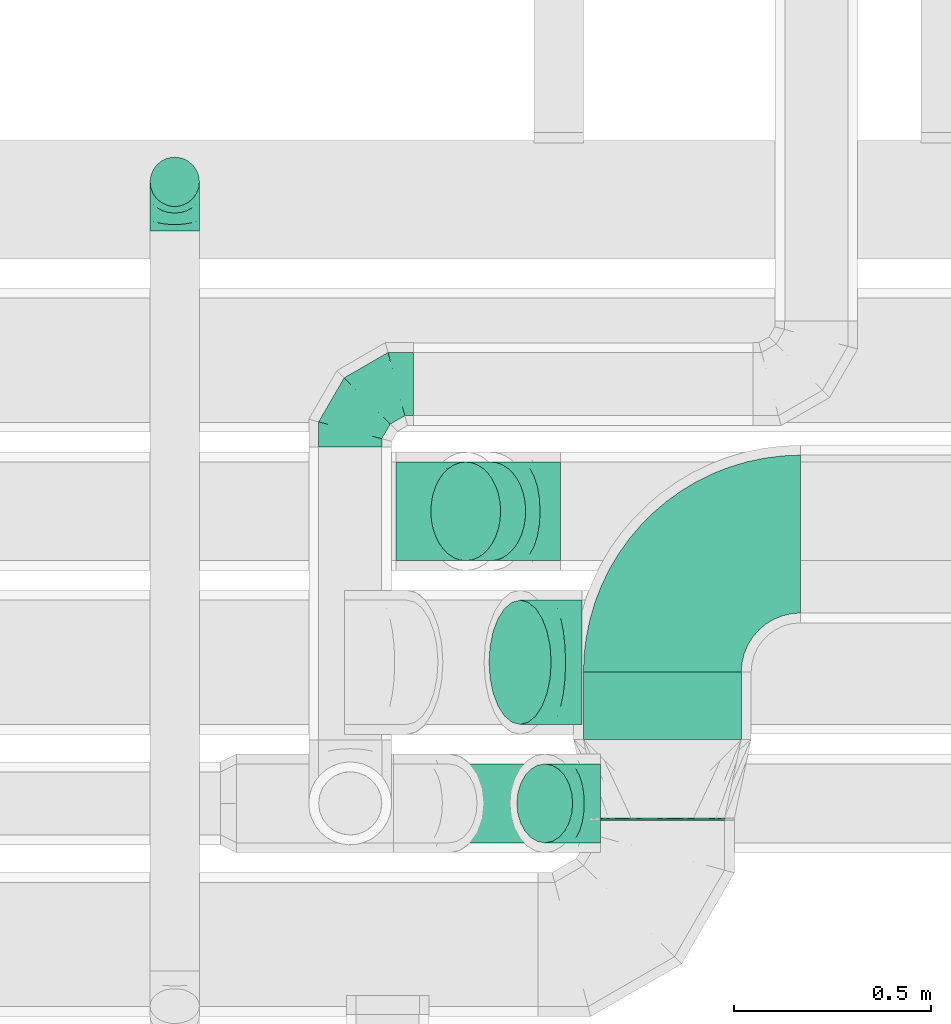
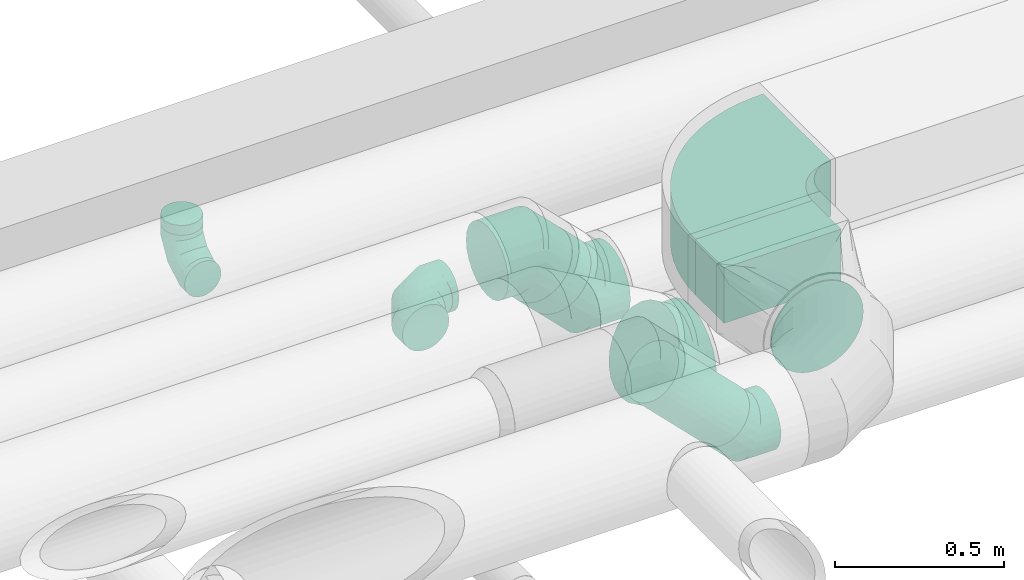
# One storey, part 58 of 92: 7 flow fittings, 5 flow segments.
"""IFC2X3 building model written with IfcOpenShell, lengths in millimetres."""

from ifc_helpers import new_model, entity, si_unit, converted_unit, derived_unit, direction, frame, frame_2d, origin, origin_2d_with_axis, place, context, subcontext, project, spatial, polyline, circle_curve, parameter, trimmed, segment, composite_curve, rectangle, circle, outline, extrude, faceted_brep, source, transform, mapped, material, type_object, type_shapes, element, save


model = new_model("IFC2X3")

# Units and contexts
model_context = context("Model", 3, precision=0.01, world=origin(), true_north=direction((6.12303176911189e-17, 1.0)))
body_context = subcontext(model_context, "Body", "Model", "MODEL_VIEW")
ifc_project = project(units=[si_unit("LENGTHUNIT", "METRE", prefix="MILLI"), si_unit("AREAUNIT", "SQUARE_METRE"), si_unit("VOLUMEUNIT", "CUBIC_METRE"), converted_unit("PLANEANGLEUNIT", "DEGREE", entity("IfcRatioMeasure", 0.0174532925199433), si_unit("PLANEANGLEUNIT", "RADIAN"), dimensions=[0, 0, 0, 0, 0, 0, 0]), si_unit("MASSUNIT", "GRAM", prefix="KILO"), derived_unit("MASSDENSITYUNIT", [(si_unit("MASSUNIT", "GRAM", prefix="KILO"), 1), (si_unit("LENGTHUNIT", "METRE"), -3)]), derived_unit("MOMENTOFINERTIAUNIT", [(si_unit("LENGTHUNIT", "METRE"), 4)]), si_unit("TIMEUNIT", "SECOND"), si_unit("FREQUENCYUNIT", "HERTZ"), si_unit("THERMODYNAMICTEMPERATUREUNIT", "DEGREE_CELSIUS"), derived_unit("THERMALTRANSMITTANCEUNIT", [(si_unit("MASSUNIT", "GRAM", prefix="KILO"), 1), (si_unit("THERMODYNAMICTEMPERATUREUNIT", "KELVIN"), -1), (si_unit("TIMEUNIT", "SECOND"), -3)]), derived_unit("VOLUMETRICFLOWRATEUNIT", [(si_unit("LENGTHUNIT", "METRE"), 3), (si_unit("TIMEUNIT", "SECOND"), -1)]), derived_unit("MASSFLOWRATEUNIT", [(si_unit("MASSUNIT", "GRAM", prefix="KILO"), 1), (si_unit("TIMEUNIT", "SECOND"), -1)]), derived_unit("ROTATIONALFREQUENCYUNIT", [(si_unit("TIMEUNIT", "SECOND"), -1)]), si_unit("ELECTRICCURRENTUNIT", "AMPERE"), si_unit("ELECTRICVOLTAGEUNIT", "VOLT"), si_unit("POWERUNIT", "WATT"), si_unit("FORCEUNIT", "NEWTON", prefix="KILO"), si_unit("ILLUMINANCEUNIT", "LUX"), si_unit("LUMINOUSFLUXUNIT", "LUMEN"), si_unit("LUMINOUSINTENSITYUNIT", "CANDELA"), derived_unit("USERDEFINED", [(si_unit("MASSUNIT", "GRAM", prefix="KILO"), -1), (si_unit("LENGTHUNIT", "METRE"), -2), (si_unit("TIMEUNIT", "SECOND"), 3), (si_unit("LUMINOUSFLUXUNIT", "LUMEN"), 1)]), derived_unit("LINEARVELOCITYUNIT", [(si_unit("LENGTHUNIT", "METRE"), 1), (si_unit("TIMEUNIT", "SECOND"), -1)]), si_unit("PRESSUREUNIT", "PASCAL"), derived_unit("USERDEFINED", [(si_unit("LENGTHUNIT", "METRE"), -2), (si_unit("MASSUNIT", "GRAM", prefix="KILO"), 1), (si_unit("TIMEUNIT", "SECOND"), -2)]), derived_unit("LINEARFORCEUNIT", [(si_unit("MASSUNIT", "GRAM", prefix="KILO"), 1), (si_unit("LENGTHUNIT", "METRE"), 1), (si_unit("TIMEUNIT", "SECOND"), -2), (si_unit("LENGTHUNIT", "METRE"), -1)]), derived_unit("PLANARFORCEUNIT", [(si_unit("MASSUNIT", "GRAM", prefix="KILO"), 1), (si_unit("LENGTHUNIT", "METRE"), 1), (si_unit("TIMEUNIT", "SECOND"), -2), (si_unit("LENGTHUNIT", "METRE"), -2)])], contexts=[model_context])

# Site, building, storey
site_placement = place(None, origin())
site = spatial("IfcSite", under=ifc_project, at=site_placement, CompositionType="ELEMENT")
building_placement = place(site_placement, origin())
building = spatial("IfcBuilding", under=site, at=building_placement, CompositionType="ELEMENT")
storey_placement = place(building_placement, frame((0.0, 0.0, 4200.0)))
storey = spatial("IfcBuildingStorey", under=building, at=storey_placement, CompositionType="ELEMENT", Elevation=4200.0)

# Flow segments
duct_segment_type_1 = type_object("IfcDuctSegmentType", PredefinedType="NOTDEFINED")
flow_segment_1_placement = place(storey_placement, frame((47020.11, 14762.0, 3257.5)))
element("IfcFlowSegment", 1, at=flow_segment_1_placement, inside=storey, type_object=duct_segment_type_1, context=body_context, shape_type="SweptSolid", body=[
    extrude(rectangle(XDim=170.00000000002, YDim=400.000000000004, at=origin_2d_with_axis()), frame((200.0, 85.0, 0.0), z_axis=(0.0, 0.0, 1.0), x_axis=(0.0, -1.0, 0.0)), (0.0, 0.0, 1.0), 200.0),
])
duct_segment_type_2 = type_object("IfcDuctSegmentType", PredefinedType="NOTDEFINED")
flow_segment_2_placement = place(storey_placement, frame((45920.46, 16110.42, 3125.0)))
element("IfcFlowSegment", 2, at=flow_segment_2_placement, inside=storey, type_object=duct_segment_type_2, context=body_context, shape_type="SweptSolid", body=[
    extrude(circle(Radius=62.5, at=origin_2d_with_axis()), frame((64.1, 64.1, 0.0)), (0.0, 0.0, 1.0), 35.3426558875469),
])
flow_segment_3_placement = place(storey_placement, frame((46607.52, 14497.9, 2986.27)))
element("IfcFlowSegment", 3, at=flow_segment_3_placement, inside=storey, type_object=duct_segment_type_2, context=body_context, shape_type="SweptSolid", body=[
    extrude(circle(Radius=100.0, at=origin_2d_with_axis()), frame((72.31, 101.6, 314.63), z_axis=(0.707106781186494, 0.0, -0.707106781186601), x_axis=(0.0, -1.0, 0.0)), (0.0, 0.0, 1.0), 342.697006973696),
])
flow_segment_4_placement = place(storey_placement, frame((46631.86, 15212.9, 3073.24)))
element("IfcFlowSegment", 4, at=flow_segment_4_placement, inside=storey, type_object=duct_segment_type_2, context=body_context, shape_type="SweptSolid", body=[
    extrude(circle(Radius=125.0, at=origin_2d_with_axis()), frame((89.98, 126.6, 153.54), z_axis=(0.707106792500144, 0.0, -0.707106769872951), x_axis=(0.0, 1.0, 0.0)), (0.0, 0.0, 1.0), 89.8780763498347),
])
flow_segment_5_placement = place(storey_placement, frame((47061.01, 14557.0, 3140.9)))
element("IfcFlowSegment", 5, at=flow_segment_5_placement, inside=storey, type_object=duct_segment_type_2, context=body_context, shape_type="SweptSolid", body=[
    extrude(circle(Radius=157.5, at=origin_2d_with_axis()), frame((159.1, 0.0, 159.1), z_axis=(0.0, 1.0, 0.0), x_axis=(1.0, 0.0, 0.0)), (0.0, 0.0, 1.0), 5.00000000002269),
])

# Flow fittings
ifc_material = material()
duct_fitting_type_1 = type_object("IfcDuctFittingType", PredefinedType="NOTDEFINED", material=ifc_material)
shared_shape_1 = source(origin(), body_context, "Body", "Brep", [
    faceted_brep([(-160.0, 0.0, -80.0), (-160.0, -20.71, -77.27), (-160.0, -40.0, -69.28), (-160.0, -56.57, -56.57), (-160.0, -69.28, -40.0), (-160.0, -77.27, -20.71), (-160.0, -80.0, 0.0), (-160.0, -77.27, 20.71), (-160.0, -69.28, 40.0), (-160.0, -56.57, 56.57), (-160.0, -40.0, 69.28), (-160.0, -20.71, 77.27), (-160.0, 0.0, 80.0), (-160.0, 20.71, 77.27), (-160.0, 40.0, 69.28), (-160.0, 56.57, 56.57), (-160.0, 69.28, 40.0), (-160.0, 77.27, 20.71), (-160.0, 80.0, 0.0), (-160.0, 77.27, -20.71), (-160.0, 69.28, -40.0), (-160.0, 56.57, -56.57), (-160.0, 40.0, -69.28), (-160.0, 20.71, -77.27), (-122.68, 20.71, 77.27), (-127.85, 40.0, 69.28), (-117.13, 0.0, 80.0), (-132.29, 56.57, 56.57), (-137.83, 77.27, 20.71), (-138.56, 80.0, 0.0), (-135.69, 69.28, 40.0), (-135.69, 69.28, -40.0), (-132.29, 56.57, -56.57), (-137.83, 77.27, -20.71), (-122.68, 20.71, -77.27), (-117.13, 0.0, -80.0), (-127.85, 40.0, -69.28), (-111.58, -20.71, -77.27), (-106.41, -40.0, -69.28), (-101.97, -56.57, -56.57), (-98.56, -69.28, -40.0), (-96.42, -77.27, -20.71), (-95.69, -80.0, 0.0), (-96.42, -77.27, 20.71), (-98.56, -69.28, 40.0), (-101.97, -56.57, 56.57), (-106.41, -40.0, 69.28), (-111.58, -20.71, 77.27), (-58.03, 58.03, 77.27), (-72.15, 72.15, 69.28), (-42.87, 42.87, 80.0), (-84.28, 84.28, 56.57), (-93.59, 93.59, 40.0), (-99.44, 99.44, 20.71), (-101.44, 101.44, 0.0), (-99.44, 99.44, -20.71), (-93.59, 93.59, -40.0), (-84.28, 84.28, -56.57), (-58.03, 58.03, -77.27), (-42.87, 42.87, -80.0), (-72.15, 72.15, -69.28), (-27.71, 27.71, -77.27), (-13.59, 13.59, -69.28), (-1.46, 1.46, -56.57), (7.85, -7.85, -40.0), (13.7, -13.7, -20.71), (15.69, -15.69, 0.0), (13.7, -13.7, 20.71), (7.85, -7.85, 40.0), (-1.46, 1.46, 56.57), (-13.59, 13.59, 69.28), (-27.71, 27.71, 77.27), (-20.71, 122.68, 77.27), (-40.0, 127.85, 69.28), (0.0, 117.13, 80.0), (-56.57, 132.29, 56.57), (-69.28, 135.69, 40.0), (-77.27, 137.83, 20.71), (-80.0, 138.56, 0.0), (-77.27, 137.83, -20.71), (-69.28, 135.69, -40.0), (-56.57, 132.29, -56.57), (-20.71, 122.68, -77.27), (0.0, 117.13, -80.0), (-40.0, 127.85, -69.28), (20.71, 111.58, -77.27), (40.0, 106.41, -69.28), (56.57, 101.97, -56.57), (69.28, 98.56, -40.0), (77.27, 96.42, -20.71), (80.0, 95.69, 0.0), (77.27, 96.42, 20.71), (69.28, 98.56, 40.0), (56.57, 101.97, 56.57), (40.0, 106.41, 69.28), (20.71, 111.58, 77.27), (-20.71, 160.0, -77.27), (-40.0, 160.0, -69.28), (-56.57, 160.0, -56.57), (-69.28, 160.0, -40.0), (-77.27, 160.0, -20.71), (-80.0, 160.0, 0.0), (-77.27, 160.0, 20.71), (-69.28, 160.0, 40.0), (-56.57, 160.0, 56.57), (-40.0, 160.0, 69.28), (-20.71, 160.0, 77.27), (0.0, 160.0, 80.0), (20.71, 160.0, 77.27), (40.0, 160.0, 69.28), (56.57, 160.0, 56.57), (69.28, 160.0, 40.0), (77.27, 160.0, 20.71), (80.0, 160.0, 0.0), (77.27, 160.0, -20.71), (69.28, 160.0, -40.0), (56.57, 160.0, -56.57), (40.0, 160.0, -69.28), (20.71, 160.0, -77.27), (0.0, 160.0, -80.0)], [[[0, 1, 2, 3, 4, 5, 6, 7, 8, 9, 10, 11, 12, 13, 14, 15, 16, 17, 18, 19, 20, 21, 22, 23]], [[24, 25, 14, 13]], [[26, 24, 13, 12]], [[14, 25, 27, 15]], [[28, 29, 18, 17]], [[30, 28, 17, 16]], [[15, 27, 30, 16]], [[20, 31, 32, 21]], [[33, 31, 20, 19]], [[18, 29, 33, 19]], [[34, 35, 0, 23]], [[36, 34, 23, 22]], [[32, 36, 22, 21]], [[1, 0, 35, 37]], [[2, 1, 37, 38]], [[3, 2, 38, 39]], [[5, 4, 40, 41]], [[6, 5, 41, 42]], [[39, 40, 4, 3]], [[6, 42, 43, 7]], [[7, 43, 44, 8]], [[8, 44, 45, 9]], [[9, 45, 46, 10]], [[10, 46, 47, 11]], [[26, 12, 11, 47]], [[48, 49, 25, 24]], [[50, 48, 24, 26]], [[27, 25, 49, 51]], [[52, 53, 28, 30]], [[51, 52, 30, 27]], [[29, 28, 53, 54]], [[55, 56, 31, 33]], [[54, 55, 33, 29]], [[32, 31, 56, 57]], [[58, 59, 35, 34]], [[60, 58, 34, 36]], [[57, 60, 36, 32]], [[37, 35, 59, 61]], [[38, 37, 61, 62]], [[39, 38, 62, 63]], [[41, 40, 64, 65]], [[42, 41, 65, 66]], [[63, 64, 40, 39]], [[43, 42, 66, 67]], [[44, 43, 67, 68]], [[68, 69, 45, 44]], [[46, 45, 69, 70]], [[47, 46, 70, 71]], [[26, 47, 71, 50]], [[72, 73, 49, 48]], [[74, 72, 48, 50]], [[51, 49, 73, 75]], [[76, 77, 53, 52]], [[75, 76, 52, 51]], [[54, 53, 77, 78]], [[79, 80, 56, 55]], [[78, 79, 55, 54]], [[57, 56, 80, 81]], [[82, 83, 59, 58]], [[84, 82, 58, 60]], [[81, 84, 60, 57]], [[61, 59, 83, 85]], [[62, 61, 85, 86]], [[63, 62, 86, 87]], [[65, 64, 88, 89]], [[66, 65, 89, 90]], [[87, 88, 64, 63]], [[67, 66, 90, 91]], [[68, 67, 91, 92]], [[92, 93, 69, 68]], [[70, 69, 93, 94]], [[71, 70, 94, 95]], [[50, 71, 95, 74]], [[96, 97, 98, 99, 100, 101, 102, 103, 104, 105, 106, 107, 108, 109, 110, 111, 112, 113, 114, 115, 116, 117, 118, 119]], [[72, 74, 107, 106]], [[73, 72, 106, 105]], [[75, 73, 105, 104]], [[77, 76, 103, 102]], [[78, 77, 102, 101]], [[75, 104, 103, 76]], [[78, 101, 100, 79]], [[79, 100, 99, 80]], [[80, 99, 98, 81]], [[84, 97, 96, 82]], [[82, 96, 119, 83]], [[84, 81, 98, 97]], [[118, 117, 86, 85]], [[119, 118, 85, 83]], [[116, 87, 86, 117]], [[88, 115, 114, 89]], [[89, 114, 113, 90]], [[115, 88, 87, 116]], [[112, 111, 92, 91]], [[113, 112, 91, 90]], [[111, 110, 93, 92]], [[95, 94, 109, 108]], [[74, 95, 108, 107]], [[110, 109, 94, 93]]]),
])
type_shapes(duct_fitting_type_1, [shared_shape_1])
flow_fitting_1_placement = place(storey_placement, frame((46429.18, 15661.98, 3000.0), z_axis=(0.0, 0.0, 1.0), x_axis=(-1.0, 0.0, 0.0)))
element("IfcFlowFitting", 6, at=flow_fitting_1_placement, inside=storey, type_object=duct_fitting_type_1, material=ifc_material, context=body_context, shape_type="MappedRepresentation", body=[
    mapped(shared_shape_1, transform((0.0, 0.0, 0.0), scale=1.0)),
])
duct_fitting_type_2 = type_object("IfcDuctFittingType", PredefinedType="NOTDEFINED", material=ifc_material)
shared_shape_2 = source(origin(), body_context, "Body", "Brep", [
    faceted_brep([(-125.0, 0.0, -62.5), (-125.0, -16.18, -60.37), (-125.0, -31.25, -54.13), (-125.0, -44.19, -44.19), (-125.0, -54.13, -31.25), (-125.0, -60.37, -16.18), (-125.0, -62.5, 0.0), (-125.0, -60.37, 16.18), (-125.0, -54.13, 31.25), (-125.0, -44.19, 44.19), (-125.0, -31.25, 54.13), (-125.0, -16.18, 60.37), (-125.0, 0.0, 62.5), (-125.0, 16.18, 60.37), (-125.0, 31.25, 54.13), (-125.0, 44.19, 44.19), (-125.0, 54.13, 31.25), (-125.0, 60.37, 16.18), (-125.0, 62.5, 0.0), (-125.0, 60.37, -16.18), (-125.0, 54.13, -31.25), (-125.0, 44.19, -44.19), (-125.0, 31.25, -54.13), (-125.0, 16.18, -60.37), (-95.84, 16.18, 60.37), (-99.88, 31.25, 54.13), (-91.51, 0.0, 62.5), (-103.35, 44.19, 44.19), (-107.68, 60.37, 16.18), (-108.25, 62.5, 0.0), (-106.01, 54.13, 31.25), (-106.01, 54.13, -31.25), (-103.35, 44.19, -44.19), (-107.68, 60.37, -16.18), (-95.84, 16.18, -60.37), (-91.51, 0.0, -62.5), (-99.88, 31.25, -54.13), (-87.17, -16.18, -60.37), (-83.13, -31.25, -54.13), (-79.66, -44.19, -44.19), (-77.0, -54.13, -31.25), (-75.33, -60.37, -16.18), (-74.76, -62.5, 0.0), (-75.33, -60.37, 16.18), (-77.0, -54.13, 31.25), (-79.66, -44.19, 44.19), (-83.13, -31.25, 54.13), (-87.17, -16.18, 60.37), (-45.34, 45.34, 60.37), (-56.37, 56.37, 54.13), (-33.49, 33.49, 62.5), (-65.85, 65.85, 44.19), (-73.12, 73.12, 31.25), (-77.69, 77.69, 16.18), (-79.25, 79.25, 0.0), (-77.69, 77.69, -16.18), (-73.12, 73.12, -31.25), (-65.85, 65.85, -44.19), (-45.34, 45.34, -60.37), (-33.49, 33.49, -62.5), (-56.37, 56.37, -54.13), (-21.65, 21.65, -60.37), (-10.62, 10.62, -54.13), (-1.14, 1.14, -44.19), (6.13, -6.13, -31.25), (10.7, -10.7, -16.18), (12.26, -12.26, 0.0), (10.7, -10.7, 16.18), (6.13, -6.13, 31.25), (-1.14, 1.14, 44.19), (-10.62, 10.62, 54.13), (-21.65, 21.65, 60.37), (-16.18, 95.84, 60.37), (-31.25, 99.88, 54.13), (0.0, 91.51, 62.5), (-44.19, 103.35, 44.19), (-54.13, 106.01, 31.25), (-60.37, 107.68, 16.18), (-62.5, 108.25, 0.0), (-60.37, 107.68, -16.18), (-54.13, 106.01, -31.25), (-44.19, 103.35, -44.19), (-16.18, 95.84, -60.37), (0.0, 91.51, -62.5), (-31.25, 99.88, -54.13), (16.18, 87.17, -60.37), (31.25, 83.13, -54.13), (44.19, 79.66, -44.19), (54.13, 77.0, -31.25), (60.37, 75.33, -16.18), (62.5, 74.76, 0.0), (60.37, 75.33, 16.18), (54.13, 77.0, 31.25), (44.19, 79.66, 44.19), (31.25, 83.13, 54.13), (16.18, 87.17, 60.37), (-16.18, 125.0, -60.37), (-31.25, 125.0, -54.13), (-44.19, 125.0, -44.19), (-54.13, 125.0, -31.25), (-60.37, 125.0, -16.18), (-62.5, 125.0, 0.0), (-60.37, 125.0, 16.18), (-54.13, 125.0, 31.25), (-44.19, 125.0, 44.19), (-31.25, 125.0, 54.13), (-16.18, 125.0, 60.37), (0.0, 125.0, 62.5), (16.18, 125.0, 60.37), (31.25, 125.0, 54.13), (44.19, 125.0, 44.19), (54.13, 125.0, 31.25), (60.37, 125.0, 16.18), (62.5, 125.0, 0.0), (60.37, 125.0, -16.18), (54.13, 125.0, -31.25), (44.19, 125.0, -44.19), (31.25, 125.0, -54.13), (16.18, 125.0, -60.37), (0.0, 125.0, -62.5)], [[[0, 1, 2, 3, 4, 5, 6, 7, 8, 9, 10, 11, 12, 13, 14, 15, 16, 17, 18, 19, 20, 21, 22, 23]], [[24, 25, 14, 13]], [[26, 24, 13, 12]], [[14, 25, 27, 15]], [[28, 29, 18, 17]], [[30, 28, 17, 16]], [[15, 27, 30, 16]], [[20, 31, 32, 21]], [[33, 31, 20, 19]], [[18, 29, 33, 19]], [[34, 35, 0, 23]], [[36, 34, 23, 22]], [[21, 32, 36, 22]], [[1, 0, 35, 37]], [[2, 1, 37, 38]], [[38, 39, 3, 2]], [[5, 4, 40, 41]], [[6, 5, 41, 42]], [[39, 40, 4, 3]], [[6, 42, 43, 7]], [[7, 43, 44, 8]], [[45, 9, 8, 44]], [[9, 45, 46, 10]], [[10, 46, 47, 11]], [[26, 12, 11, 47]], [[48, 49, 25, 24]], [[50, 48, 24, 26]], [[27, 25, 49, 51]], [[52, 53, 28, 30]], [[51, 52, 30, 27]], [[29, 28, 53, 54]], [[55, 56, 31, 33]], [[54, 55, 33, 29]], [[57, 32, 31, 56]], [[58, 59, 35, 34]], [[60, 58, 34, 36]], [[57, 60, 36, 32]], [[37, 35, 59, 61]], [[38, 37, 61, 62]], [[39, 38, 62, 63]], [[41, 40, 64, 65]], [[42, 41, 65, 66]], [[63, 64, 40, 39]], [[43, 42, 66, 67]], [[44, 43, 67, 68]], [[68, 69, 45, 44]], [[46, 45, 69, 70]], [[47, 46, 70, 71]], [[26, 47, 71, 50]], [[72, 73, 49, 48]], [[74, 72, 48, 50]], [[51, 49, 73, 75]], [[76, 77, 53, 52]], [[75, 76, 52, 51]], [[54, 53, 77, 78]], [[79, 80, 56, 55]], [[78, 79, 55, 54]], [[81, 57, 56, 80]], [[82, 83, 59, 58]], [[84, 82, 58, 60]], [[81, 84, 60, 57]], [[61, 59, 83, 85]], [[62, 61, 85, 86]], [[63, 62, 86, 87]], [[65, 64, 88, 89]], [[66, 65, 89, 90]], [[87, 88, 64, 63]], [[67, 66, 90, 91]], [[68, 67, 91, 92]], [[92, 93, 69, 68]], [[70, 69, 93, 94]], [[71, 70, 94, 95]], [[50, 71, 95, 74]], [[96, 97, 98, 99, 100, 101, 102, 103, 104, 105, 106, 107, 108, 109, 110, 111, 112, 113, 114, 115, 116, 117, 118, 119]], [[72, 74, 107, 106]], [[73, 72, 106, 105]], [[75, 73, 105, 104]], [[77, 76, 103, 102]], [[78, 77, 102, 101]], [[75, 104, 103, 76]], [[78, 101, 100, 79]], [[79, 100, 99, 80]], [[80, 99, 98, 81]], [[96, 119, 83, 82]], [[97, 96, 82, 84]], [[84, 81, 98, 97]], [[83, 119, 118, 85]], [[85, 118, 117, 86]], [[116, 87, 86, 117]], [[88, 115, 114, 89]], [[89, 114, 113, 90]], [[115, 88, 87, 116]], [[91, 90, 113, 112]], [[92, 91, 112, 111]], [[111, 110, 93, 92]], [[95, 94, 109, 108]], [[74, 95, 108, 107]], [[110, 109, 94, 93]]]),
])
type_shapes(duct_fitting_type_2, [shared_shape_2])
flow_fitting_2_placement = place(storey_placement, frame((45984.55, 16174.51, 3000.0), z_axis=(-1.0, 0.0, 0.0), x_axis=(0.0, 0.0, -1.0)))
element("IfcFlowFitting", 7, at=flow_fitting_2_placement, inside=storey, type_object=duct_fitting_type_2, material=ifc_material, context=body_context, shape_type="MappedRepresentation", body=[
    mapped(shared_shape_2, transform((0.0, 0.0, 0.0), scale=1.0)),
])
duct_fitting_type_3 = type_object("IfcDuctFittingType", PredefinedType="NOTDEFINED", material=ifc_material)
shared_shape_3 = source(origin(), body_context, "Body", "Brep", [
    faceted_brep([(-82.84, 0.0, -100.0), (-82.84, -25.88, -96.59), (-82.84, -50.0, -86.6), (-82.84, -70.71, -70.71), (-82.84, -86.6, -50.0), (-82.84, -96.59, -25.88), (-82.84, -100.0, 0.0), (-82.84, -96.59, 25.88), (-82.84, -86.6, 50.0), (-82.84, -70.71, 70.71), (-82.84, -50.0, 86.6), (-82.84, -25.88, 96.59), (-82.84, 0.0, 100.0), (-82.84, 25.88, 96.59), (-82.84, 50.0, 86.6), (-82.84, 70.71, 70.71), (-82.84, 86.6, 50.0), (-82.84, 96.59, 25.88), (-82.84, 100.0, 0.0), (-82.84, 96.59, -25.88), (-82.84, 86.6, -50.0), (-82.84, 70.71, -70.71), (-82.84, 50.0, -86.6), (-82.84, 25.88, -96.59), (-10.72, 25.88, 96.59), (-20.71, 50.0, 86.6), (0.0, 0.0, 100.0), (-29.29, 70.71, 70.71), (-35.87, 86.6, 50.0), (-40.01, 96.59, 25.88), (-41.42, 100.0, 0.0), (-40.01, 96.59, -25.88), (-35.87, 86.6, -50.0), (-29.29, 70.71, -70.71), (-10.72, 25.88, -96.59), (0.0, 0.0, -100.0), (-20.71, 50.0, -86.6), (10.72, -25.88, -96.59), (20.71, -50.0, -86.6), (29.29, -70.71, -70.71), (35.87, -86.6, -50.0), (40.01, -96.59, -25.88), (41.42, -100.0, 0.0), (40.01, -96.59, 25.88), (35.87, -86.6, 50.0), (29.29, -70.71, 70.71), (20.71, -50.0, 86.6), (10.72, -25.88, 96.59), (58.58, 58.58, 100.0), (40.28, 76.88, 96.59), (23.22, 93.93, 86.6), (8.58, 108.58, 70.71), (-2.66, 119.82, 50.0), (-9.72, 126.88, 25.88), (-12.13, 129.29, 0.0), (-9.72, 126.88, -25.88), (-2.66, 119.82, -50.0), (8.58, 108.58, -70.71), (23.22, 93.93, -86.6), (40.28, 76.88, -96.59), (58.58, 58.58, -100.0), (76.88, 40.28, -96.59), (93.93, 23.22, -86.6), (108.58, 8.58, -70.71), (119.82, -2.66, -50.0), (126.88, -9.72, -25.88), (129.29, -12.13, 0.0), (126.88, -9.72, 25.88), (119.82, -2.66, 50.0), (108.58, 8.58, 70.71), (93.93, 23.22, 86.6), (76.88, 40.28, 96.59)], [[[0, 1, 2, 3, 4, 5, 6, 7, 8, 9, 10, 11, 12, 13, 14, 15, 16, 17, 18, 19, 20, 21, 22, 23]], [[24, 25, 14, 13]], [[26, 24, 13, 12]], [[14, 25, 27, 15]], [[28, 29, 17, 16]], [[28, 16, 15, 27]], [[30, 18, 17, 29]], [[31, 32, 20, 19]], [[30, 31, 19, 18]], [[32, 33, 21, 20]], [[34, 35, 0, 23]], [[36, 34, 23, 22]], [[33, 36, 22, 21]], [[1, 0, 35, 37]], [[2, 1, 37, 38]], [[38, 39, 3, 2]], [[5, 4, 40, 41]], [[6, 5, 41, 42]], [[39, 40, 4, 3]], [[6, 42, 43, 7]], [[7, 43, 44, 8]], [[8, 44, 45, 9]], [[9, 45, 46, 10]], [[10, 46, 47, 11]], [[26, 12, 11, 47]], [[24, 26, 48, 49]], [[25, 24, 49, 50]], [[27, 25, 50, 51]], [[29, 28, 52, 53]], [[30, 29, 53, 54]], [[51, 52, 28, 27]], [[30, 54, 55, 31]], [[31, 55, 56, 32]], [[57, 33, 32, 56]], [[36, 58, 59, 34]], [[34, 59, 60, 35]], [[58, 36, 33, 57]], [[35, 60, 61, 37]], [[37, 61, 62, 38]], [[63, 39, 38, 62]], [[40, 64, 65, 41]], [[41, 65, 66, 42]], [[64, 40, 39, 63]], [[43, 42, 66, 67]], [[44, 43, 67, 68]], [[68, 69, 45, 44]], [[47, 46, 70, 71]], [[26, 47, 71, 48]], [[69, 70, 46, 45]], [[59, 58, 57, 56, 55, 54, 53, 52, 51, 50, 49, 48, 71, 70, 69, 68, 67, 66, 65, 64, 63, 62, 61, 60]]]),
])
type_shapes(duct_fitting_type_3, [shared_shape_3])
flow_fitting_3_placement = place(storey_placement, frame((46980.73, 14599.5, 3000.0), z_axis=(0.0, -1.0, 0.0), x_axis=(0.70710678118654, 0.0, -0.707106781186555)))
element("IfcFlowFitting", 8, at=flow_fitting_3_placement, inside=storey, type_object=duct_fitting_type_3, material=ifc_material, context=body_context, shape_type="MappedRepresentation", body=[
    mapped(shared_shape_3, transform((0.0, 0.0, 0.0), scale=1.0)),
])
duct_fitting_type_4 = type_object("IfcDuctFittingType", PredefinedType="NOTDEFINED", material=ifc_material)
shared_shape_4 = source(origin(), body_context, "Body", "Brep", [
    faceted_brep([(-103.55, 0.0, -125.0), (-103.55, -32.35, -120.74), (-103.55, -62.5, -108.25), (-103.55, -88.39, -88.39), (-103.55, -108.25, -62.5), (-103.55, -120.74, -32.35), (-103.55, -125.0, 0.0), (-103.55, -120.74, 32.35), (-103.55, -108.25, 62.5), (-103.55, -88.39, 88.39), (-103.55, -62.5, 108.25), (-103.55, -32.35, 120.74), (-103.55, 0.0, 125.0), (-103.55, 32.35, 120.74), (-103.55, 62.5, 108.25), (-103.55, 88.39, 88.39), (-103.55, 108.25, 62.5), (-103.55, 120.74, 32.35), (-103.55, 125.0, 0.0), (-103.55, 120.74, -32.35), (-103.55, 108.25, -62.5), (-103.55, 88.39, -88.39), (-103.55, 62.5, -108.25), (-103.55, 32.35, -120.74), (-13.4, 32.35, 120.74), (-25.89, 62.5, 108.25), (0.0, 0.0, 125.0), (-36.61, 88.39, 88.39), (-44.84, 108.25, 62.5), (-50.01, 120.74, 32.35), (-51.78, 125.0, 0.0), (-50.01, 120.74, -32.35), (-44.84, 108.25, -62.5), (-36.61, 88.39, -88.39), (-13.4, 32.35, -120.74), (0.0, 0.0, -125.0), (-25.89, 62.5, -108.25), (13.4, -32.35, -120.74), (25.89, -62.5, -108.25), (36.61, -88.39, -88.39), (44.84, -108.25, -62.5), (50.01, -120.74, -32.35), (51.78, -125.0, 0.0), (50.01, -120.74, 32.35), (44.84, -108.25, 62.5), (36.61, -88.39, 88.39), (25.89, -62.5, 108.25), (13.4, -32.35, 120.74), (73.22, 73.22, 125.0), (50.35, 96.1, 120.74), (29.03, 117.42, 108.25), (10.72, 135.72, 88.39), (-3.32, 149.77, 62.5), (-12.15, 158.6, 32.35), (-15.17, 161.61, 0.0), (-12.15, 158.6, -32.35), (-3.32, 149.77, -62.5), (10.72, 135.72, -88.39), (29.03, 117.42, -108.25), (50.35, 96.1, -120.74), (73.22, 73.22, -125.0), (96.1, 50.35, -120.74), (117.42, 29.03, -108.25), (135.72, 10.72, -88.39), (149.77, -3.32, -62.5), (158.6, -12.15, -32.35), (161.61, -15.17, 0.0), (158.6, -12.15, 32.35), (149.77, -3.32, 62.5), (135.72, 10.72, 88.39), (117.42, 29.03, 108.25), (96.1, 50.35, 120.74)], [[[0, 1, 2, 3, 4, 5, 6, 7, 8, 9, 10, 11, 12, 13, 14, 15, 16, 17, 18, 19, 20, 21, 22, 23]], [[24, 25, 14, 13]], [[26, 24, 13, 12]], [[14, 25, 27, 15]], [[28, 29, 17, 16]], [[28, 16, 15, 27]], [[30, 18, 17, 29]], [[31, 32, 20, 19]], [[30, 31, 19, 18]], [[32, 33, 21, 20]], [[34, 35, 0, 23]], [[36, 34, 23, 22]], [[33, 36, 22, 21]], [[1, 0, 35, 37]], [[2, 1, 37, 38]], [[38, 39, 3, 2]], [[5, 4, 40, 41]], [[6, 5, 41, 42]], [[39, 40, 4, 3]], [[6, 42, 43, 7]], [[7, 43, 44, 8]], [[8, 44, 45, 9]], [[9, 45, 46, 10]], [[10, 46, 47, 11]], [[26, 12, 11, 47]], [[24, 26, 48, 49]], [[25, 24, 49, 50]], [[27, 25, 50, 51]], [[29, 28, 52, 53]], [[30, 29, 53, 54]], [[51, 52, 28, 27]], [[30, 54, 55, 31]], [[31, 55, 56, 32]], [[57, 33, 32, 56]], [[36, 58, 59, 34]], [[34, 59, 60, 35]], [[58, 36, 33, 57]], [[35, 60, 61, 37]], [[37, 61, 62, 38]], [[63, 39, 38, 62]], [[40, 64, 65, 41]], [[41, 65, 66, 42]], [[64, 40, 39, 63]], [[43, 42, 66, 67]], [[44, 43, 67, 68]], [[68, 69, 45, 44]], [[47, 46, 70, 71]], [[26, 47, 71, 48]], [[69, 70, 46, 45]], [[59, 58, 57, 56, 55, 54, 53, 52, 51, 50, 49, 48, 71, 70, 69, 68, 67, 66, 65, 64, 63, 62, 61, 60]]]),
])
type_shapes(duct_fitting_type_4, [shared_shape_4])
for number, where, z_axis, x_axis in (
    (9, (46858.62, 15339.5, 3090.0), (0.0, -1.0, 0.0), (0.707106792500234, 0.0, -0.707106769872861)),
    (10, (46648.62, 15339.5, 3300.0), (0.0, -1.0, 0.0), (-0.707106792500239, 0.0, 0.707106769872856)),
):
    element("IfcFlowFitting", number, at=place(storey_placement, frame(where, z_axis=z_axis, x_axis=x_axis)), inside=storey, type_object=duct_fitting_type_4, material=ifc_material, context=body_context, shape_type="MappedRepresentation", body=[
        mapped(shared_shape_4, transform((0.0, 0.0, 0.0), scale=1.0)),
    ])
duct_fitting_type_5 = type_object("IfcDuctFittingType", PredefinedType="NOTDEFINED", material=ifc_material)
shared_shape_5 = source(origin(), body_context, "Body", "Brep", [
    faceted_brep([(-84.4, 0.0, -157.5), (-84.4, -40.76, -152.13), (-84.4, -78.75, -136.4), (-84.4, -111.37, -111.37), (-84.4, -136.4, -78.75), (-84.4, -152.13, -40.76), (-84.4, -157.5, 0.0), (-84.4, -152.13, 40.76), (-84.4, -136.4, 78.75), (-84.4, -111.37, 111.37), (-84.4, -78.75, 136.4), (-84.4, -40.76, 152.13), (-84.4, 0.0, 157.5), (-84.4, 40.76, 152.13), (-84.4, 78.75, 136.4), (-84.4, 111.37, 111.37), (-84.4, 136.4, 78.75), (-84.4, 152.13, 40.76), (-84.4, 157.5, 0.0), (-84.4, 152.13, -40.76), (-84.4, 136.4, -78.75), (-84.4, 111.37, -111.37), (-84.4, 78.75, -136.4), (-84.4, 40.76, -152.13), (-10.92, 40.76, 152.13), (-21.1, 78.75, 136.4), (0.0, 0.0, 157.5), (-29.84, 111.37, 111.37), (-40.76, 152.13, 40.76), (-42.2, 157.5, 0.0), (-36.55, 136.4, 78.75), (-36.55, 136.4, -78.75), (-29.84, 111.37, -111.37), (-40.76, 152.13, -40.76), (-10.92, 40.76, -152.13), (0.0, 0.0, -157.5), (-21.1, 78.75, -136.4), (10.92, -40.76, -152.13), (21.1, -78.75, -136.4), (29.84, -111.37, -111.37), (36.55, -136.4, -78.75), (40.76, -152.13, -40.76), (42.2, -157.5, 0.0), (40.76, -152.13, 40.76), (36.55, -136.4, 78.75), (29.84, -111.37, 111.37), (21.1, -78.75, 136.4), (10.92, -40.76, 152.13), (52.71, 77.5, 152.13), (33.72, 110.4, 136.4), (73.1, 42.2, 157.5), (17.41, 138.65, 111.37), (4.9, 160.33, 78.75), (-2.97, 173.95, 40.76), (-5.65, 178.6, 0.0), (-2.97, 173.95, -40.76), (4.9, 160.33, -78.75), (17.41, 138.65, -111.37), (33.72, 110.4, -136.4), (52.71, 77.5, -152.13), (73.1, 42.2, -157.5), (93.48, 6.9, -152.13), (112.47, -26.0, -136.4), (128.78, -54.25, -111.37), (141.3, -75.92, -78.75), (149.16, -89.55, -40.76), (151.85, -94.2, 0.0), (149.16, -89.55, 40.76), (141.3, -75.92, 78.75), (128.78, -54.25, 111.37), (112.47, -26.0, 136.4), (93.48, 6.9, 152.13)], [[[0, 1, 2, 3, 4, 5, 6, 7, 8, 9, 10, 11, 12, 13, 14, 15, 16, 17, 18, 19, 20, 21, 22, 23]], [[24, 25, 14, 13]], [[26, 24, 13, 12]], [[14, 25, 27, 15]], [[28, 29, 18, 17]], [[30, 28, 17, 16]], [[15, 27, 30, 16]], [[20, 31, 32, 21]], [[33, 31, 20, 19]], [[18, 29, 33, 19]], [[34, 35, 0, 23]], [[36, 34, 23, 22]], [[32, 36, 22, 21]], [[1, 0, 35, 37]], [[2, 1, 37, 38]], [[38, 39, 3, 2]], [[5, 4, 40, 41]], [[6, 5, 41, 42]], [[39, 40, 4, 3]], [[6, 42, 43, 7]], [[7, 43, 44, 8]], [[8, 44, 45, 9]], [[9, 45, 46, 10]], [[10, 46, 47, 11]], [[26, 12, 11, 47]], [[48, 49, 25, 24]], [[50, 48, 24, 26]], [[27, 25, 49, 51]], [[28, 30, 52, 53]], [[29, 28, 53, 54]], [[51, 52, 30, 27]], [[29, 54, 55, 33]], [[33, 55, 56, 31]], [[57, 32, 31, 56]], [[36, 58, 59, 34]], [[34, 59, 60, 35]], [[58, 36, 32, 57]], [[35, 60, 61, 37]], [[37, 61, 62, 38]], [[63, 39, 38, 62]], [[40, 64, 65, 41]], [[41, 65, 66, 42]], [[64, 40, 39, 63]], [[43, 42, 66, 67]], [[44, 43, 67, 68]], [[68, 69, 45, 44]], [[47, 46, 70, 71]], [[26, 47, 71, 50]], [[69, 70, 46, 45]], [[59, 58, 57, 56, 55, 54, 53, 52, 51, 49, 48, 50, 71, 70, 69, 68, 67, 66, 65, 64, 63, 62, 61, 60]]]),
])
type_shapes(duct_fitting_type_5, [shared_shape_5])
flow_fitting_4_placement = place(storey_placement, frame((46932.68, 14957.0, 3050.0), z_axis=(0.0, 1.0, 0.0), x_axis=(-1.0, 0.0, 0.0)))
element("IfcFlowFitting", 11, at=flow_fitting_4_placement, inside=storey, type_object=duct_fitting_type_5, material=ifc_material, context=body_context, shape_type="MappedRepresentation", body=[
    mapped(shared_shape_5, transform((0.0, 0.0, 0.0), scale=1.0)),
])
duct_fitting_type_6 = type_object("IfcDuctFittingType", PredefinedType="NOTDEFINED", material=ifc_material)
shared_shape_6 = source(origin(), body_context, "Body", "SweptSolid", [
    extrude(outline(composite_curve([segment(polyline([(-375.0, -175.0), (25.0, -175.0)]), True, "CONTINUOUS"), segment(trimmed(circle_curve(frame_2d((175.0, -175.0), x_axis=(0.0, 1.0)), 150.0), [parameter(0.0)], [parameter(90.0000000000001)], True, "PARAMETER"), False, "CONTINUOUS"), segment(polyline([(175.0, -25.0), (175.0, 375.0)]), True, "CONTINUOUS"), segment(trimmed(circle_curve(frame_2d((175.0, -175.0), x_axis=(0.0, 1.0)), 550.0), [parameter(0.0)], [parameter(90.0)], True, "PARAMETER"), True, "CONTINUOUS")], self_intersect=False)), frame((-175.0, 175.0, -100.0), z_axis=(0.0, 0.0, 1.0), x_axis=(-1.0, 0.0, 0.0)), (0.0, 0.0, 1.0), 200.0),
])
type_shapes(duct_fitting_type_6, [shared_shape_6])
flow_fitting_5_placement = place(storey_placement, frame((47220.11, 15282.0, 3357.5), z_axis=(0.0, 0.0, 1.0), x_axis=(-1.0, 0.0, 0.0)))
element("IfcFlowFitting", 12, at=flow_fitting_5_placement, inside=storey, type_object=duct_fitting_type_6, material=ifc_material, context=body_context, shape_type="MappedRepresentation", body=[
    mapped(shared_shape_6, transform((0.0, 0.0, 0.0), scale=1.0)),
])

save(model, "model.ifc")
